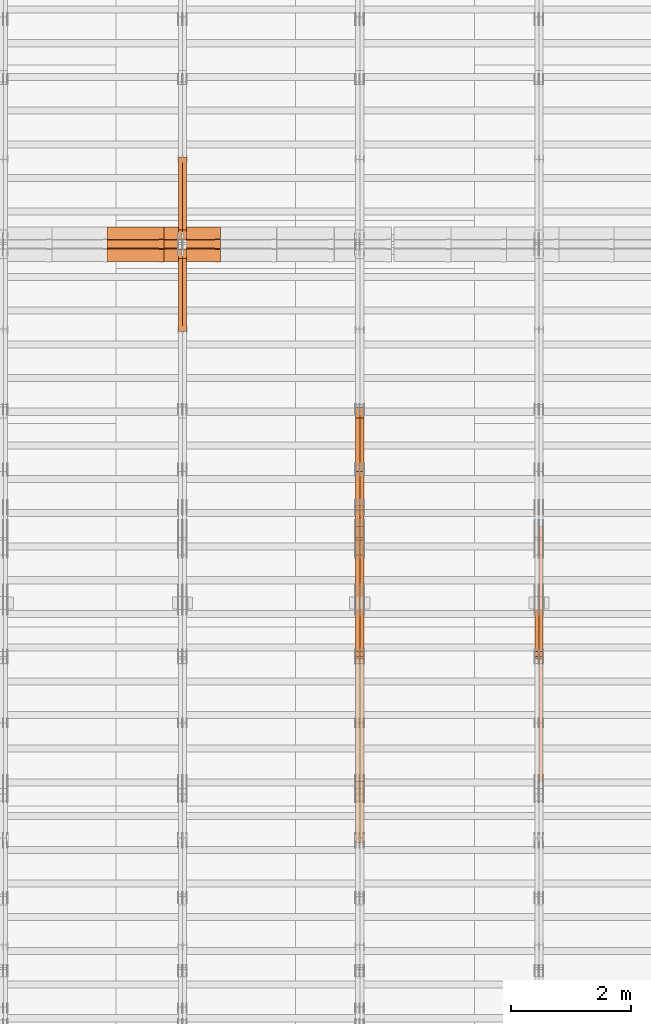
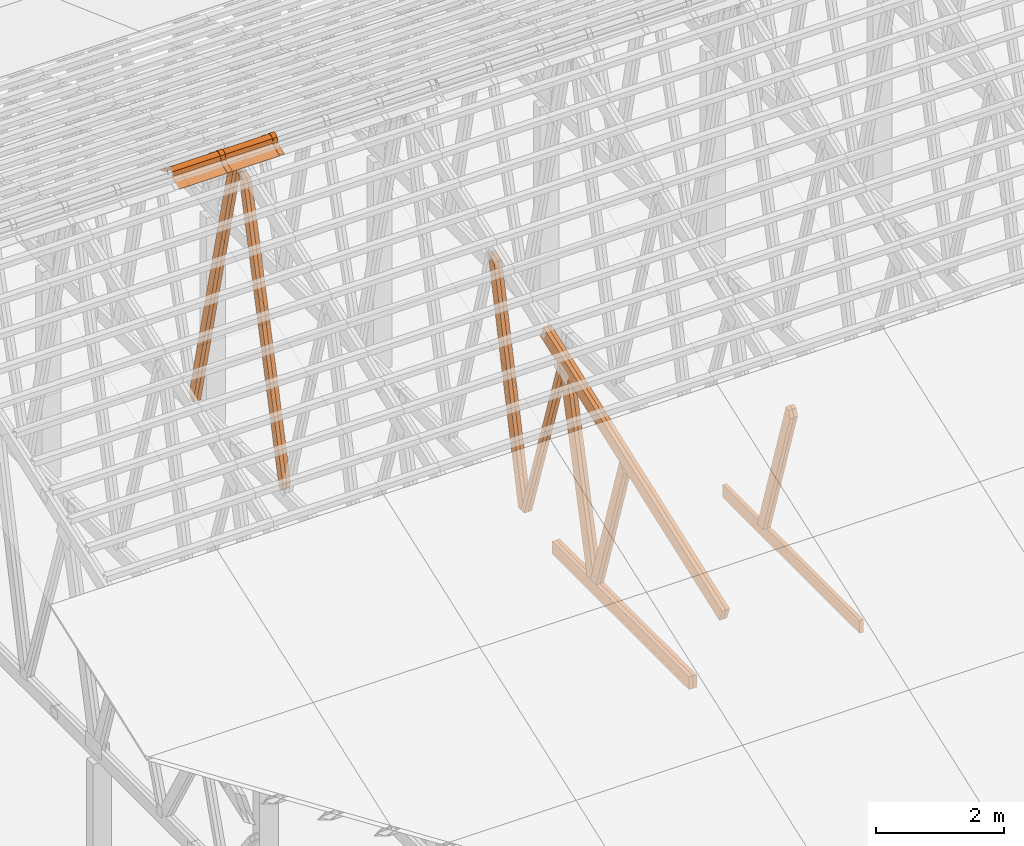
# One storey, part 18 of 189: 23 proxies.
"""IFC2X3 building model written with IfcOpenShell, lengths in millimetres."""

from ifc_helpers import new_model, entity, si_unit, converted_unit, derived_unit, direction, frame, frame_2d, origin, origin_2d_with_axis, place, context, subcontext, project, spatial, polyline, circle_curve, parameter, trimmed, segment, composite_curve, rectangle, outline, extrude, source, transform, mapped, material, type_object, type_shapes, element, save


model = new_model("IFC2X3")

# Units and contexts
model_context = context("Model", 3, precision=0.01, world=origin(), true_north=direction((6.12303176911189e-17, 1.0)))
body_context = subcontext(model_context, "Body", "Model", "MODEL_VIEW")
ifc_project = project(units=[si_unit("LENGTHUNIT", "METRE", prefix="MILLI"), si_unit("AREAUNIT", "SQUARE_METRE"), si_unit("VOLUMEUNIT", "CUBIC_METRE"), converted_unit("PLANEANGLEUNIT", "DEGREE", entity("IfcRatioMeasure", 0.0174532925199433), si_unit("PLANEANGLEUNIT", "RADIAN"), dimensions=[0, 0, 0, 0, 0, 0, 0]), si_unit("MASSUNIT", "GRAM", prefix="KILO"), derived_unit("MASSDENSITYUNIT", [(si_unit("MASSUNIT", "GRAM", prefix="KILO"), 1), (si_unit("LENGTHUNIT", "METRE"), -3)]), si_unit("TIMEUNIT", "SECOND"), si_unit("FREQUENCYUNIT", "HERTZ"), si_unit("THERMODYNAMICTEMPERATUREUNIT", "DEGREE_CELSIUS"), derived_unit("THERMALTRANSMITTANCEUNIT", [(si_unit("MASSUNIT", "GRAM", prefix="KILO"), 1), (si_unit("THERMODYNAMICTEMPERATUREUNIT", "KELVIN"), -1), (si_unit("TIMEUNIT", "SECOND"), -3)]), derived_unit("VOLUMETRICFLOWRATEUNIT", [(si_unit("LENGTHUNIT", "METRE"), 3), (si_unit("TIMEUNIT", "SECOND"), -1)]), si_unit("ELECTRICCURRENTUNIT", "AMPERE"), si_unit("ELECTRICVOLTAGEUNIT", "VOLT"), si_unit("POWERUNIT", "WATT"), si_unit("FORCEUNIT", "NEWTON"), si_unit("ILLUMINANCEUNIT", "LUX"), si_unit("LUMINOUSFLUXUNIT", "LUMEN"), si_unit("LUMINOUSINTENSITYUNIT", "CANDELA"), derived_unit("USERDEFINED", [(si_unit("MASSUNIT", "GRAM", prefix="KILO"), -1), (si_unit("LENGTHUNIT", "METRE"), -2), (si_unit("TIMEUNIT", "SECOND"), 3), (si_unit("LUMINOUSFLUXUNIT", "LUMEN"), 1)]), derived_unit("LINEARVELOCITYUNIT", [(si_unit("LENGTHUNIT", "METRE"), 1), (si_unit("TIMEUNIT", "SECOND"), -1)]), si_unit("PRESSUREUNIT", "PASCAL"), derived_unit("USERDEFINED", [(si_unit("LENGTHUNIT", "METRE"), -2), (si_unit("MASSUNIT", "GRAM", prefix="KILO"), 1), (si_unit("TIMEUNIT", "SECOND"), -2)])], contexts=[model_context])

# Site, building, storey
site_placement = place(None, origin())
site = spatial("IfcSite", under=ifc_project, at=site_placement, CompositionType="ELEMENT")
building_placement = place(site_placement, origin())
building = spatial("IfcBuilding", under=site, at=building_placement, CompositionType="ELEMENT")
storey_placement = place(building_placement, origin())
storey = spatial("IfcBuildingStorey", under=building, at=storey_placement, Name="Default", CompositionType="ELEMENT", Elevation=0.0)

# Proxies
ifc_material_1 = material(Name="IfcSurfaceStyle #67314")
building_element_proxy_type_1 = type_object("IfcBuildingElementProxyType", Name="T1-W4 67312", PredefinedType="NOTDEFINED", material=ifc_material_1)
shared_shape_1 = source(origin(), body_context, "Body", "SweptSolid", [
    extrude(outline(polyline([(-1688.09292256655, -85.0003489723785), (1071.44998120742, -85.0003489723785), (1178.19407811536, -0.00016040063201781), (1181.35435681367, 85.0004291726946), (-1742.9054935699, 85.0004291726946), (-1688.09292256655, -85.0003489723785)])), frame((1181.35446122976, 85.0007670757732, 0.0), z_axis=(0.0, 0.0, 1.0), x_axis=(-1.0, 0.0, 0.0)), (0.0, 0.0, 1.0), 69.9999999999998),
])
type_shapes(building_element_proxy_type_1, [shared_shape_1])
proxy_1_placement = place(building_placement, frame((12300.0, 7937.17021143291, 3028.170124945), z_axis=(-1.0, 0.0, 0.0), x_axis=(0.0, 0.306868406216492, -0.951751953644514)))
element("IfcBuildingElementProxy", 1, at=proxy_1_placement, inside=storey, type_object=building_element_proxy_type_1, material=ifc_material_1, Name="T1-W4", context=body_context, shape_type="MappedRepresentation", body=[
    mapped(shared_shape_1, transform((0.0, 0.0, 0.0), scale=1.0)),
])
ifc_material_2 = material(Name="IfcSurfaceStyle #67248")
building_element_proxy_type_2 = type_object("IfcBuildingElementProxyType", Name="T1-W4 67246", PredefinedType="NOTDEFINED", material=ifc_material_2)
shared_shape_2 = source(origin(), body_context, "Body", "SweptSolid", [
    extrude(outline(polyline([(-1688.09292256655, -85.0003489723785), (1071.44998120742, -85.0003489723785), (1178.19407811536, -0.00016040063201781), (1181.35435681367, 85.0004291726946), (-1742.9054935699, 85.0004291726946), (-1688.09292256655, -85.0003489723785)])), frame((1181.35446122976, 85.0007670757732, 0.0), z_axis=(0.0, 0.0, 1.0), x_axis=(-1.0, 0.0, 0.0)), (0.0, 0.0, 1.0), 69.9999999999998),
])
type_shapes(building_element_proxy_type_2, [shared_shape_2])
proxy_2_placement = place(building_placement, frame((12230.0, 7937.17021143291, 3028.170124945), z_axis=(-1.0, 0.0, 0.0), x_axis=(0.0, 0.306868406216492, -0.951751953644514)))
element("IfcBuildingElementProxy", 2, at=proxy_2_placement, inside=storey, type_object=building_element_proxy_type_2, material=ifc_material_2, Name="T1-W4", context=body_context, shape_type="MappedRepresentation", body=[
    mapped(shared_shape_2, transform((0.0, 0.0, 0.0), scale=1.0)),
])
ifc_material_3 = material(Name="IfcSurfaceStyle #64236")
building_element_proxy_type_3 = type_object("IfcBuildingElementProxyType", Name="T1-B6 64234", PredefinedType="NOTDEFINED", material=ifc_material_3)
shared_shape_3 = source(origin(), body_context, "Body", "SweptSolid", [
    extrude(rectangle(XDim=4266.763671875, YDim=245.000000000001, at=origin_2d_with_axis()), frame((2133.3818359375, 122.500000000001, 0.0), z_axis=(0.0, 0.0, 1.0), x_axis=(-1.0, 0.0, 0.0)), (0.0, 0.0, 1.0), 69.9999999999997),
])
type_shapes(building_element_proxy_type_3, [shared_shape_3])
proxy_3_placement = place(building_placement, frame((12300.0, 5762.466796875, 245.0), z_axis=(-1.0, 0.0, 0.0), x_axis=(0.0, 1.0, 0.0)))
element("IfcBuildingElementProxy", 3, at=proxy_3_placement, inside=storey, type_object=building_element_proxy_type_3, material=ifc_material_3, Name="T1-B6", context=body_context, shape_type="MappedRepresentation", body=[
    mapped(shared_shape_3, transform((0.0, 0.0, 0.0), scale=1.0)),
])
ifc_material_4 = material(Name="IfcSurfaceStyle #52316")
building_element_proxy_type_4 = type_object("IfcBuildingElementProxyType", Name="T1-W3 52314", PredefinedType="NOTDEFINED", material=ifc_material_4)
shared_shape_4 = source(origin(), body_context, "Body", "SweptSolid", [
    extrude(outline(polyline([(-2625.55080717397, -84.9998286237256), (1749.48871563991, -84.9998286237256), (1768.20584427244, 0.000602085469291858), (1625.445846867, 85.0000405971208), (-2517.58959960538, 84.9990145648612), (-2625.55080717397, -84.9998286237256)])), frame((1768.20584427244, 85.0000405971208, 0.0), z_axis=(0.0, 0.0, 1.0), x_axis=(-1.0, 0.0, 0.0)), (0.0, 0.0, 1.0), 69.9999999999997),
])
type_shapes(building_element_proxy_type_4, [shared_shape_4])
proxy_4_placement = place(building_placement, frame((9300.0, 10918.6728403286, 263.278932236374), z_axis=(-1.0, 0.0, 0.0), x_axis=(0.0, 0.215047682154604, 0.976603550269982)))
element("IfcBuildingElementProxy", 4, at=proxy_4_placement, inside=storey, type_object=building_element_proxy_type_4, material=ifc_material_4, Name="T1-W3", context=body_context, shape_type="MappedRepresentation", body=[
    mapped(shared_shape_4, transform((0.0, 0.0, 0.0), scale=1.0)),
])
ifc_material_5 = material(Name="IfcSurfaceStyle #52250")
building_element_proxy_type_5 = type_object("IfcBuildingElementProxyType", Name="T1-W3 52248", PredefinedType="NOTDEFINED", material=ifc_material_5)
shared_shape_5 = source(origin(), body_context, "Body", "SweptSolid", [
    extrude(outline(polyline([(-2625.55080717397, -84.9998286237256), (1749.48871563991, -84.9998286237256), (1768.20584427244, 0.000602085469291858), (1625.445846867, 85.0000405971208), (-2517.58959960538, 84.9990145648612), (-2625.55080717397, -84.9998286237256)])), frame((1768.20584427244, 85.0000405971208, 0.0), z_axis=(0.0, 0.0, 1.0), x_axis=(-1.0, 0.0, 0.0)), (0.0, 0.0, 1.0), 69.9999999999997),
])
type_shapes(building_element_proxy_type_5, [shared_shape_5])
proxy_5_placement = place(building_placement, frame((9230.0, 10918.6728403286, 263.278932236374), z_axis=(-1.0, 0.0, 0.0), x_axis=(0.0, 0.215047682154604, 0.976603550269982)))
element("IfcBuildingElementProxy", 5, at=proxy_5_placement, inside=storey, type_object=building_element_proxy_type_5, material=ifc_material_5, Name="T1-W3", context=body_context, shape_type="MappedRepresentation", body=[
    mapped(shared_shape_5, transform((0.0, 0.0, 0.0), scale=1.0)),
])
ifc_material_6 = material(Name="IfcSurfaceStyle #52052")
building_element_proxy_type_6 = type_object("IfcBuildingElementProxyType", Name="T1-W7 52050", PredefinedType="NOTDEFINED", material=ifc_material_6)
shared_shape_6 = source(origin(), body_context, "Body", "SweptSolid", [
    extrude(outline(polyline([(-2158.15323194511, -47.5001976605119), (1398.58481981178, -47.5001976605119), (1473.93376219819, -0.000131511554346808), (1475.30069254941, 47.5002634162891), (-2189.66604261427, 47.5002634162891), (-2158.15323194511, -47.5001976605119)])), frame((1475.30069254941, 47.5002634162891, 0.0), z_axis=(0.0, 0.0, 1.0), x_axis=(-1.0, 0.0, 0.0)), (0.0, 0.0, 1.0), 69.9999999999998),
])
type_shapes(building_element_proxy_type_6, [shared_shape_6])
proxy_6_placement = place(building_placement, frame((9300.0, 9847.787109375, 3723.57788085937), z_axis=(-1.0, 0.0, 0.0), x_axis=(0.0, 0.314845237923105, -0.949143021971475)))
element("IfcBuildingElementProxy", 6, at=proxy_6_placement, inside=storey, type_object=building_element_proxy_type_6, material=ifc_material_6, Name="T1-W7", context=body_context, shape_type="MappedRepresentation", body=[
    mapped(shared_shape_6, transform((0.0, 0.0, 0.0), scale=1.0)),
])
ifc_material_7 = material(Name="IfcSurfaceStyle #51986")
building_element_proxy_type_7 = type_object("IfcBuildingElementProxyType", Name="T1-W7 51984", PredefinedType="NOTDEFINED", material=ifc_material_7)
shared_shape_7 = source(origin(), body_context, "Body", "SweptSolid", [
    extrude(outline(polyline([(-2158.15323194511, -47.5001976605119), (1398.58481981178, -47.5001976605119), (1473.93376219819, -0.000131511554346808), (1475.30069254941, 47.5002634162891), (-2189.66604261427, 47.5002634162891), (-2158.15323194511, -47.5001976605119)])), frame((1475.30069254941, 47.5002634162891, 0.0), z_axis=(0.0, 0.0, 1.0), x_axis=(-1.0, 0.0, 0.0)), (0.0, 0.0, 1.0), 69.9999999999998),
])
type_shapes(building_element_proxy_type_7, [shared_shape_7])
proxy_7_placement = place(building_placement, frame((9230.0, 9847.787109375, 3723.57788085937), z_axis=(-1.0, 0.0, 0.0), x_axis=(0.0, 0.314845237923105, -0.949143021971475)))
element("IfcBuildingElementProxy", 7, at=proxy_7_placement, inside=storey, type_object=building_element_proxy_type_7, material=ifc_material_7, Name="T1-W7", context=body_context, shape_type="MappedRepresentation", body=[
    mapped(shared_shape_7, transform((0.0, 0.0, 0.0), scale=1.0)),
])
ifc_material_8 = material(Name="IfcSurfaceStyle #51788")
building_element_proxy_type_8 = type_object("IfcBuildingElementProxyType", Name="T1-W1 51786", PredefinedType="NOTDEFINED", material=ifc_material_8)
shared_shape_8 = source(origin(), body_context, "Body", "SweptSolid", [
    extrude(outline(polyline([(-2144.69382208629, -109.99948311278), (1421.70798092021, -109.99948311278), (1448.88116133745, -0.000392715405943322), (1271.09900468242, 109.999679470483), (-1996.99432485378, 109.999679470483), (-2144.69382208629, -109.99948311278)])), frame((1448.88130194731, 110.000176487146, 0.0), z_axis=(0.0, 0.0, 1.0), x_axis=(-1.0, 0.0, 0.0)), (0.0, 0.0, 1.0), 69.9999999999998),
])
type_shapes(building_element_proxy_type_8, [shared_shape_8])
proxy_8_placement = place(building_placement, frame((9300.0, 8727.74270166583, 271.380182391418), z_axis=(-1.0, 0.0, 0.0), x_axis=(0.0, 0.239819839925978, 0.970817410421691)))
element("IfcBuildingElementProxy", 8, at=proxy_8_placement, inside=storey, type_object=building_element_proxy_type_8, material=ifc_material_8, Name="T1-W1", context=body_context, shape_type="MappedRepresentation", body=[
    mapped(shared_shape_8, transform((0.0, 0.0, 0.0), scale=1.0)),
])
ifc_material_9 = material(Name="IfcSurfaceStyle #51722")
building_element_proxy_type_9 = type_object("IfcBuildingElementProxyType", Name="T1-W1 51720", PredefinedType="NOTDEFINED", material=ifc_material_9)
shared_shape_9 = source(origin(), body_context, "Body", "SweptSolid", [
    extrude(outline(polyline([(-2144.69382208629, -109.99948311278), (1421.70798092021, -109.99948311278), (1448.88116133745, -0.000392715405943322), (1271.09900468242, 109.999679470483), (-1996.99432485378, 109.999679470483), (-2144.69382208629, -109.99948311278)])), frame((1448.88130194731, 110.000176487146, 0.0), z_axis=(0.0, 0.0, 1.0), x_axis=(-1.0, 0.0, 0.0)), (0.0, 0.0, 1.0), 69.9999999999998),
])
type_shapes(building_element_proxy_type_9, [shared_shape_9])
proxy_9_placement = place(building_placement, frame((9230.0, 8727.74270166583, 271.380182391418), z_axis=(-1.0, 0.0, 0.0), x_axis=(0.0, 0.239819839925978, 0.970817410421691)))
element("IfcBuildingElementProxy", 9, at=proxy_9_placement, inside=storey, type_object=building_element_proxy_type_9, material=ifc_material_9, Name="T1-W1", context=body_context, shape_type="MappedRepresentation", body=[
    mapped(shared_shape_9, transform((0.0, 0.0, 0.0), scale=1.0)),
])
ifc_material_10 = material(Name="IfcSurfaceStyle #51524")
building_element_proxy_type_10 = type_object("IfcBuildingElementProxyType", Name="T1-W4 51522", PredefinedType="NOTDEFINED", material=ifc_material_10)
shared_shape_10 = source(origin(), body_context, "Body", "SweptSolid", [
    extrude(outline(polyline([(-1688.09292256655, -85.0003489723785), (1071.44998120742, -85.0003489723785), (1178.19407811536, -0.00016040063201781), (1181.35435681367, 85.0004291726946), (-1742.9054935699, 85.0004291726946), (-1688.09292256655, -85.0003489723785)])), frame((1181.35446122976, 85.0007670757732, 0.0), z_axis=(0.0, 0.0, 1.0), x_axis=(-1.0, 0.0, 0.0)), (0.0, 0.0, 1.0), 69.9999999999998),
])
type_shapes(building_element_proxy_type_10, [shared_shape_10])
proxy_10_placement = place(building_placement, frame((9300.0, 7937.17021143291, 3028.170124945), z_axis=(-1.0, 0.0, 0.0), x_axis=(0.0, 0.306868406216492, -0.951751953644514)))
element("IfcBuildingElementProxy", 10, at=proxy_10_placement, inside=storey, type_object=building_element_proxy_type_10, material=ifc_material_10, Name="T1-W4", context=body_context, shape_type="MappedRepresentation", body=[
    mapped(shared_shape_10, transform((0.0, 0.0, 0.0), scale=1.0)),
])
ifc_material_11 = material(Name="IfcSurfaceStyle #51458")
building_element_proxy_type_11 = type_object("IfcBuildingElementProxyType", Name="T1-W4 51456", PredefinedType="NOTDEFINED", material=ifc_material_11)
shared_shape_11 = source(origin(), body_context, "Body", "SweptSolid", [
    extrude(outline(polyline([(-1688.09292256655, -85.0003489723785), (1071.44998120742, -85.0003489723785), (1178.19407811536, -0.00016040063201781), (1181.35435681367, 85.0004291726946), (-1742.9054935699, 85.0004291726946), (-1688.09292256655, -85.0003489723785)])), frame((1181.35446122976, 85.0007670757732, 0.0), z_axis=(0.0, 0.0, 1.0), x_axis=(-1.0, 0.0, 0.0)), (0.0, 0.0, 1.0), 69.9999999999998),
])
type_shapes(building_element_proxy_type_11, [shared_shape_11])
proxy_11_placement = place(building_placement, frame((9230.0, 7937.17021143291, 3028.170124945), z_axis=(-1.0, 0.0, 0.0), x_axis=(0.0, 0.306868406216492, -0.951751953644514)))
element("IfcBuildingElementProxy", 11, at=proxy_11_placement, inside=storey, type_object=building_element_proxy_type_11, material=ifc_material_11, Name="T1-W4", context=body_context, shape_type="MappedRepresentation", body=[
    mapped(shared_shape_11, transform((0.0, 0.0, 0.0), scale=1.0)),
])
ifc_material_12 = material(Name="IfcSurfaceStyle #48446")
building_element_proxy_type_12 = type_object("IfcBuildingElementProxyType", Name="T1-B6 48444", PredefinedType="NOTDEFINED", material=ifc_material_12)
shared_shape_12 = source(origin(), body_context, "Body", "SweptSolid", [
    extrude(rectangle(XDim=4266.763671875, YDim=245.000000000001, at=origin_2d_with_axis()), frame((2133.3818359375, 122.500000000001, 0.0), z_axis=(0.0, 0.0, 1.0), x_axis=(-1.0, 0.0, 0.0)), (0.0, 0.0, 1.0), 69.9999999999997),
])
type_shapes(building_element_proxy_type_12, [shared_shape_12])
proxy_12_placement = place(building_placement, frame((9300.0, 5762.466796875, 245.0), z_axis=(-1.0, 0.0, 0.0), x_axis=(0.0, 1.0, 0.0)))
element("IfcBuildingElementProxy", 12, at=proxy_12_placement, inside=storey, type_object=building_element_proxy_type_12, material=ifc_material_12, Name="T1-B6", context=body_context, shape_type="MappedRepresentation", body=[
    mapped(shared_shape_12, transform((0.0, 0.0, 0.0), scale=1.0)),
])
ifc_material_13 = material(Name="IfcSurfaceStyle #48389")
building_element_proxy_type_13 = type_object("IfcBuildingElementProxyType", Name="T1-B6 48387", PredefinedType="NOTDEFINED", material=ifc_material_13)
shared_shape_13 = source(origin(), body_context, "Body", "SweptSolid", [
    extrude(rectangle(XDim=4266.763671875, YDim=245.000000000001, at=origin_2d_with_axis()), frame((2133.3818359375, 122.500000000001, 0.0), z_axis=(0.0, 0.0, 1.0), x_axis=(-1.0, 0.0, 0.0)), (0.0, 0.0, 1.0), 69.9999999999997),
])
type_shapes(building_element_proxy_type_13, [shared_shape_13])
proxy_13_placement = place(building_placement, frame((9230.0, 5762.466796875, 245.0), z_axis=(-1.0, 0.0, 0.0), x_axis=(0.0, 1.0, 0.0)))
element("IfcBuildingElementProxy", 13, at=proxy_13_placement, inside=storey, type_object=building_element_proxy_type_13, material=ifc_material_13, Name="T1-B6", context=body_context, shape_type="MappedRepresentation", body=[
    mapped(shared_shape_13, transform((0.0, 0.0, 0.0), scale=1.0)),
])
ifc_material_14 = material(Name="IfcSurfaceStyle #48086")
building_element_proxy_type_14 = type_object("IfcBuildingElementProxyType", Name="T1-T1 48084", PredefinedType="NOTDEFINED", material=ifc_material_14)
shared_shape_14 = source(origin(), body_context, "Body", "SweptSolid", [
    extrude(outline(polyline([(-2964.99981923522, -122.500027388895), (2964.99982426074, -122.500027388895), (2964.99984011048, 122.500027388895), (-2964.99984513599, 122.500027388895), (-2964.99981923522, -122.500027388895)])), frame((2965.00021857317, 122.500056320695, 0.0), z_axis=(0.0, 0.0, 1.0), x_axis=(-1.0, 0.0, 0.0)), (0.0, 0.0, 1.0), 69.9999999999996),
])
type_shapes(building_element_proxy_type_14, [shared_shape_14])
proxy_14_placement = place(building_placement, frame((9300.0, 10391.0374749089, 3921.30478975487), z_axis=(-1.0, 0.0, 0.0), x_axis=(0.0, -0.939692620785908, -0.342020143325669)))
element("IfcBuildingElementProxy", 14, at=proxy_14_placement, inside=storey, type_object=building_element_proxy_type_14, material=ifc_material_14, Name="T1-T1", context=body_context, shape_type="MappedRepresentation", body=[
    mapped(shared_shape_14, transform((0.0, 0.0, 0.0), scale=1.0)),
])
ifc_material_15 = material(Name="IfcSurfaceStyle #48029")
building_element_proxy_type_15 = type_object("IfcBuildingElementProxyType", Name="T1-T1 48027", PredefinedType="NOTDEFINED", material=ifc_material_15)
shared_shape_15 = source(origin(), body_context, "Body", "SweptSolid", [
    extrude(outline(polyline([(-2964.99981923522, -122.500027388895), (2964.99982426074, -122.500027388895), (2964.99984011048, 122.500027388895), (-2964.99984513599, 122.500027388895), (-2964.99981923522, -122.500027388895)])), frame((2965.00021857317, 122.500056320695, 0.0), z_axis=(0.0, 0.0, 1.0), x_axis=(-1.0, 0.0, 0.0)), (0.0, 0.0, 1.0), 69.9999999999996),
])
type_shapes(building_element_proxy_type_15, [shared_shape_15])
proxy_15_placement = place(building_placement, frame((9230.0, 10391.0374749089, 3921.30478975487), z_axis=(-1.0, 0.0, 0.0), x_axis=(0.0, -0.939692620785908, -0.342020143325669)))
element("IfcBuildingElementProxy", 15, at=proxy_15_placement, inside=storey, type_object=building_element_proxy_type_15, material=ifc_material_15, Name="T1-T1", context=body_context, shape_type="MappedRepresentation", body=[
    mapped(shared_shape_15, transform((0.0, 0.0, 0.0), scale=1.0)),
])
ifc_material_16 = material(Name="IfcSurfaceStyle #37054")
building_element_proxy_type_16 = type_object("IfcBuildingElementProxyType", Name="T1-W5 37052", PredefinedType="NOTDEFINED", material=ifc_material_16)
shared_shape_16 = source(origin(), body_context, "Body", "SweptSolid", [
    extrude(outline(polyline([(-3233.61216530572, -72.4999091305202), (2153.79187521892, -72.4999091305202), (2171.36968478227, -7.18521572819375e-05), (2045.62106208646, 72.4999450565989), (-3137.17045678193, 72.4999450565989), (-3233.61216530572, -72.4999091305202)])), frame((2171.36968478227, 72.500192121173, 0.0), z_axis=(0.0, 0.0, 1.0), x_axis=(-1.0, 0.0, 0.0)), (0.0, 0.0, 1.0), 69.9999999999997),
])
type_shapes(building_element_proxy_type_16, [shared_shape_16])
proxy_16_placement = place(building_placement, frame((6335.0, 13261.0146935344, 262.082919891325), z_axis=(-1.0, 0.0, 0.0), x_axis=(0.0, 0.235625623344066, 0.97184389982328)))
element("IfcBuildingElementProxy", 16, at=proxy_16_placement, inside=storey, type_object=building_element_proxy_type_16, material=ifc_material_16, Name="T1-W5", context=body_context, shape_type="MappedRepresentation", body=[
    mapped(shared_shape_16, transform((0.0, 0.0, 0.0), scale=1.0)),
])
ifc_material_17 = material(Name="IfcSurfaceStyle #36988")
building_element_proxy_type_17 = type_object("IfcBuildingElementProxyType", Name="T1-W5 36986", PredefinedType="NOTDEFINED", material=ifc_material_17)
shared_shape_17 = source(origin(), body_context, "Body", "SweptSolid", [
    extrude(outline(polyline([(-3233.61216530572, -72.4999091305202), (2153.79187521892, -72.4999091305202), (2171.36968478227, -7.18521572819375e-05), (2045.62106208646, 72.4999450565989), (-3137.17045678193, 72.4999450565989), (-3233.61216530572, -72.4999091305202)])), frame((2171.36968478227, 72.500192121173, 0.0), z_axis=(0.0, 0.0, 1.0), x_axis=(-1.0, 0.0, 0.0)), (0.0, 0.0, 1.0), 69.9999999999997),
])
type_shapes(building_element_proxy_type_17, [shared_shape_17])
proxy_17_placement = place(building_placement, frame((6265.0, 13261.0146935344, 262.082919891325), z_axis=(-1.0, 0.0, 0.0), x_axis=(0.0, 0.235625623344066, 0.97184389982328)))
element("IfcBuildingElementProxy", 17, at=proxy_17_placement, inside=storey, type_object=building_element_proxy_type_17, material=ifc_material_17, Name="T1-W5", context=body_context, shape_type="MappedRepresentation", body=[
    mapped(shared_shape_17, transform((0.0, 0.0, 0.0), scale=1.0)),
])
ifc_material_18 = material(Name="IfcSurfaceStyle #36922")
building_element_proxy_type_18 = type_object("IfcBuildingElementProxyType", Name="T1-W5 36920", PredefinedType="NOTDEFINED", material=ifc_material_18)
shared_shape_18 = source(origin(), body_context, "Body", "SweptSolid", [
    extrude(outline(polyline([(-3137.17045678193, -72.5002081306407), (2045.62106208646, -72.5002081306408), (2171.36968478227, 5.58426931168476e-05), (2153.79187521892, 72.5001802092942), (-3233.61216530572, 72.5001802092942), (-3137.17045678193, -72.5002081306407)])), frame((2171.36968478227, 72.5001802092942, 0.0), z_axis=(0.0, 0.0, 1.0), x_axis=(-1.0, 0.0, 0.0)), (0.0, 0.0, 1.0), 69.9999999999997),
])
type_shapes(building_element_proxy_type_18, [shared_shape_18])
proxy_18_placement = place(building_placement, frame((6335.0, 16098.0675635854, 227.917113003597), z_axis=(-1.0, 0.0, 0.0), x_axis=(0.0, -0.235625623344066, 0.971843899823279)))
element("IfcBuildingElementProxy", 18, at=proxy_18_placement, inside=storey, type_object=building_element_proxy_type_18, material=ifc_material_18, Name="T1-W5", context=body_context, shape_type="MappedRepresentation", body=[
    mapped(shared_shape_18, transform((0.0, 0.0, 0.0), scale=1.0)),
])
ifc_material_19 = material(Name="IfcSurfaceStyle #36856")
building_element_proxy_type_19 = type_object("IfcBuildingElementProxyType", Name="T1-W5 36854", PredefinedType="NOTDEFINED", material=ifc_material_19)
shared_shape_19 = source(origin(), body_context, "Body", "SweptSolid", [
    extrude(outline(polyline([(-3137.17045678193, -72.5002081306407), (2045.62106208646, -72.5002081306408), (2171.36968478227, 5.58426931168476e-05), (2153.79187521892, 72.5001802092942), (-3233.61216530572, 72.5001802092942), (-3137.17045678193, -72.5002081306407)])), frame((2171.36968478227, 72.5001802092942, 0.0), z_axis=(0.0, 0.0, 1.0), x_axis=(-1.0, 0.0, 0.0)), (0.0, 0.0, 1.0), 69.9999999999997),
])
type_shapes(building_element_proxy_type_19, [shared_shape_19])
proxy_19_placement = place(building_placement, frame((6265.0, 16098.0675635854, 227.917113003597), z_axis=(-1.0, 0.0, 0.0), x_axis=(0.0, -0.235625623344066, 0.971843899823279)))
element("IfcBuildingElementProxy", 19, at=proxy_19_placement, inside=storey, type_object=building_element_proxy_type_19, material=ifc_material_19, Name="T1-W5", context=body_context, shape_type="MappedRepresentation", body=[
    mapped(shared_shape_19, transform((0.0, 0.0, 0.0), scale=1.0)),
])
ifc_material_20 = material()
building_element_proxy_type_20 = type_object("IfcBuildingElementProxyType", Name="P75", PredefinedType="NOTDEFINED", material=ifc_material_20)
shared_shape_20 = source(origin(), body_context, "Body", "SweptSolid", [
    extrude(outline(composite_curve([segment(polyline([(-69.4623915065845, -4.60763114971976), (47.4521071665907, -4.60763114971981)]), True, "CONTINUOUS"), segment(trimmed(circle_curve(frame_2d((119.940978060963, 14.6372018310859), x_axis=(-0.966518278591622, -0.256597773077395)), 75.0), [parameter(6.61555373744412e-13)], [parameter(180.0)], True, "PARAMETER"), True, "CONTINUOUS"), segment(polyline([(192.429848955335, 33.882034811891), (182.764666169419, 31.3160570811166)]), True, "CONTINUOUS"), segment(trimmed(circle_curve(frame_2d((119.940978060963, 14.6372018310859), x_axis=(-0.966518278591622, -0.256597773077395)), 65.0), [parameter(1.06866637297174e-12)], [parameter(180.0)], True, "PARAMETER"), False, "CONTINUOUS"), segment(polyline([(57.1172899525073, -2.04165341894578), (47.4521071665911, 5.39236885028051)]), True, "CONTINUOUS"), segment(polyline([(47.4521071665911, 5.39236885028052), (-70.7672243976422, 5.39236885028094)]), True, "CONTINUOUS"), segment(polyline([(-70.7672243976422, 5.39236885028094), (-194.776190618495, -27.5303655446341)]), True, "CONTINUOUS"), segment(polyline([(-194.776190618495, -27.5303655446341), (-192.210212887721, -37.1955483305503)]), True, "CONTINUOUS"), segment(polyline([(-192.210212887721, -37.1955483305503), (-69.4623915065845, -4.60763114971974)]), True, "CONTINUOUS")], self_intersect=False)), frame((0.0, 106.775760402721, -56.5599052870917), z_axis=(1.0, 0.0, 0.0), x_axis=(0.0, -0.820468487122275, 0.571691754041709)), (0.0, 0.0, 1.0), 867.000000000001),
    extrude(outline(composite_curve([segment(polyline([(62.2906866429439, -18.428943356533), (189.290686642944, -18.428943356533)]), True, "CONTINUOUS"), segment(polyline([(189.290686642944, -18.428943356533), (189.290686642944, -8.42894335653292)]), True, "CONTINUOUS"), segment(polyline([(189.290686642944, -8.42894335653292), (62.2906866429439, -8.42894335653294)]), True, "CONTINUOUS"), segment(polyline([(62.2906866429439, -8.42894335653294), (-41.0348065006093, 19.0026034957362)]), True, "CONTINUOUS"), segment(trimmed(circle_curve(frame_2d((-125.709313357056, 11.5710566434651), x_axis=(1.0, 0.0)), 85.0), [parameter(5.01577186738723)], [parameter(180.0)], True, "PARAMETER"), True, "CONTINUOUS"), segment(polyline([(-210.709313357056, 11.5710566434656), (-200.709313357056, 11.5710566434656)]), True, "CONTINUOUS"), segment(trimmed(circle_curve(frame_2d((-125.709313357056, 11.5710566434651), x_axis=(1.0, 0.0)), 75.0), [parameter(3.05333249420498e-13)], [parameter(180.0)], True, "PARAMETER"), False, "CONTINUOUS"), segment(polyline([(-50.7093133570542, 11.5710566434655), (62.290686642944, -18.4289433565322)]), True, "CONTINUOUS")], self_intersect=False)), frame((867.0, 114.170579674061, -53.8683539143053), z_axis=(1.0, 0.0, 0.0), x_axis=(0.0, 0.939692620785914, -0.342020143325653)), (0.0, 0.0, 1.0), 86.9999999999998),
])
type_shapes(building_element_proxy_type_20, [shared_shape_20])
for number, where, name in (
    (20, (5943.91649737545, 14755.0000438632, 5865.69618295448), "P75, generic model20:P75"),
    (21, (5003.91649737545, 14755.0000438632, 5865.69618295448), "P75, generic model20:P75"),
):
    element("IfcBuildingElementProxy", number, at=place(storey_placement, frame(where)), inside=storey, type_object=building_element_proxy_type_20, material=ifc_material_20, Name=name, ObjectType="P75, generic model20:P75", context=body_context, shape_type="MappedRepresentation", body=[
        mapped(shared_shape_20, transform((0.0, 0.0, 0.0), scale=1.0)),
    ])
building_element_proxy_type_21 = type_object("IfcBuildingElementProxyType", Name="P75", PredefinedType="NOTDEFINED", material=ifc_material_20)
shared_shape_21 = source(origin(), body_context, "Body", "SweptSolid", [
    extrude(outline(composite_curve([segment(polyline([(68.3189789579817, 13.3705352460084), (195.318978957982, 13.3705352460084)]), True, "CONTINUOUS"), segment(polyline([(195.318978957982, 13.3705352460084), (195.318978957982, 23.3705352460084)]), True, "CONTINUOUS"), segment(polyline([(195.318978957982, 23.3705352460084), (67.014146066922, 23.3705352460088)]), True, "CONTINUOUS"), segment(polyline([(67.014146066922, 23.3705352460088), (-47.2469987727929, -6.96428196807339)]), True, "CONTINUOUS"), segment(polyline([(-47.2469987727929, -6.96428196807339), (-54.6810210420187, -16.62946475399)]), True, "CONTINUOUS"), segment(trimmed(circle_curve(frame_2d((-119.681021042019, -16.6294647539896), x_axis=(1.0, 0.0)), 65.0), [parameter(180.0)], [parameter(359.999999999999)], True, "PARAMETER"), False, "CONTINUOUS"), segment(polyline([(-184.681021042019, -16.6294647539905), (-194.681021042019, -16.6294647539901)]), True, "CONTINUOUS"), segment(trimmed(circle_curve(frame_2d((-119.681021042019, -16.6294647539896), x_axis=(1.0, 0.0)), 75.0), [parameter(180.0)], [parameter(359.999999999999)], True, "PARAMETER"), True, "CONTINUOUS"), segment(polyline([(-44.6810210420183, -16.6294647539898), (68.3189789579816, 13.3705352460083)]), True, "CONTINUOUS")], self_intersect=False)), frame((0.0, -106.775760402721, -56.5599052870916), z_axis=(1.0, 0.0, 0.0), x_axis=(0.0, -0.939692620785914, -0.342020143325654)), (0.0, 0.0, 1.0), 867.000000000001),
    extrude(outline(composite_curve([segment(polyline([(-64.9339130518847, 1.82825913317695), (-187.681734433021, -30.7596580476538)]), True, "CONTINUOUS"), segment(polyline([(-187.681734433021, -30.7596580476538), (-185.115756702247, -40.4248408335702)]), True, "CONTINUOUS"), segment(polyline([(-185.115756702247, -40.4248408335702), (-62.3679353211107, -7.83692365273935)]), True, "CONTINUOUS"), segment(polyline([(-62.3679353211107, -7.83692365273935), (44.5369162809878, -7.83692365273935)]), True, "CONTINUOUS"), segment(trimmed(circle_curve(frame_2d((124.469456515662, 21.0730921139827), x_axis=(-0.966518278591636, -0.256597773077402)), 85.0), [parameter(5.01577186738723)], [parameter(180.0)], True, "PARAMETER"), True, "CONTINUOUS"), segment(polyline([(206.623510195951, 42.8839028255618), (196.958327410034, 40.3179250947878)]), True, "CONTINUOUS"), segment(trimmed(circle_curve(frame_2d((124.469456515662, 21.0730921139827), x_axis=(-0.966518278591636, -0.256597773077402)), 75.0), [parameter(3.05333249420498e-13)], [parameter(180.0)], True, "PARAMETER"), False, "CONTINUOUS"), segment(polyline([(51.9805856212887, 1.82825913317622), (-64.9339130518846, 1.82825913317621)]), True, "CONTINUOUS")], self_intersect=False)), frame((867.0, -114.170579674061, -53.868353914305), z_axis=(-1.0, 0.0, 0.0), x_axis=(0.0, 0.820468487122275, 0.571691754041709)), (0.0, 0.0, -1.0), 86.9999999999998),
])
type_shapes(building_element_proxy_type_21, [shared_shape_21])
for number, where, name in (
    (22, (5943.91649737545, 14745.0000384614, 5850.69618295448), "P75, generic model20:P75"),
    (23, (5003.91649737545, 14745.0000384614, 5850.69618295448), "P75, generic model20:P75"),
):
    element("IfcBuildingElementProxy", number, at=place(storey_placement, frame(where)), inside=storey, type_object=building_element_proxy_type_21, material=ifc_material_20, Name=name, ObjectType="P75, generic model20:P75", context=body_context, shape_type="MappedRepresentation", body=[
        mapped(shared_shape_21, transform((0.0, 0.0, 0.0), scale=1.0)),
    ])

save(model, "model.ifc")
